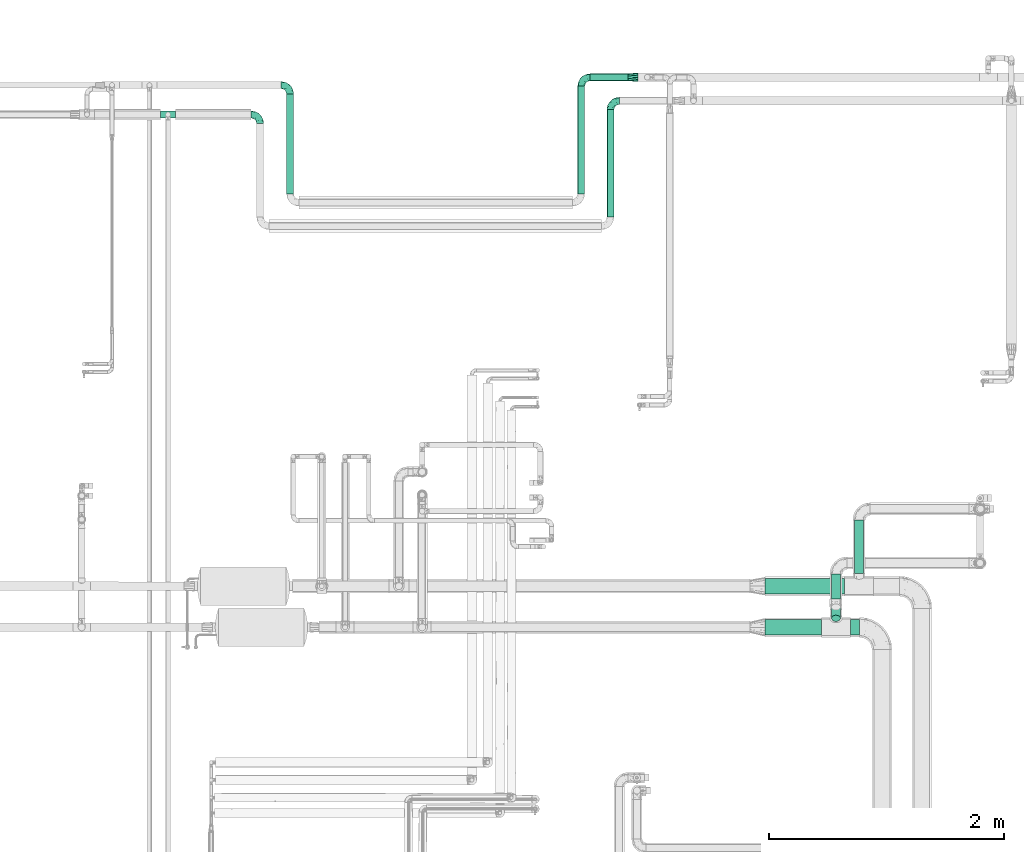
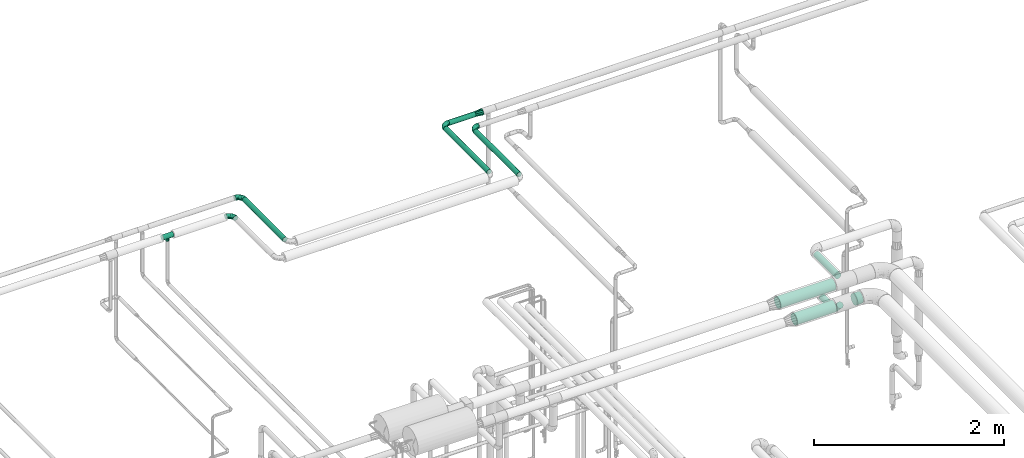
# One storey, part 582 of 827: 10 flow segments, 6 flow fittings.
"""IFC2X3 building model written with IfcOpenShell, lengths in millimetres."""

from ifc_helpers import new_model, entity, si_unit, converted_unit, derived_unit, direction, frame, origin, origin_2d_with_axis, place, context, subcontext, project, spatial, circle, extrude, faceted_brep, source, transform, mapped, material, type_object, type_shapes, element, save


model = new_model("IFC2X3")

# Units and contexts
model_context = context("Model", 3, precision=0.01, world=origin(), true_north=direction((6.12303176911189e-17, 1.0)))
body_context = subcontext(model_context, "Body", "Model", "MODEL_VIEW")
ifc_project = project(units=[si_unit("LENGTHUNIT", "METRE", prefix="MILLI"), si_unit("AREAUNIT", "SQUARE_METRE"), si_unit("VOLUMEUNIT", "CUBIC_METRE"), converted_unit("PLANEANGLEUNIT", "DEGREE", entity("IfcRatioMeasure", 0.0174532925199433), si_unit("PLANEANGLEUNIT", "RADIAN"), dimensions=[0, 0, 0, 0, 0, 0, 0]), si_unit("MASSUNIT", "GRAM", prefix="KILO"), derived_unit("MASSDENSITYUNIT", [(si_unit("MASSUNIT", "GRAM", prefix="KILO"), 1), (si_unit("LENGTHUNIT", "METRE"), -3)]), derived_unit("MOMENTOFINERTIAUNIT", [(si_unit("LENGTHUNIT", "METRE"), 4)]), si_unit("TIMEUNIT", "SECOND"), si_unit("FREQUENCYUNIT", "HERTZ"), si_unit("THERMODYNAMICTEMPERATUREUNIT", "DEGREE_CELSIUS"), derived_unit("THERMALTRANSMITTANCEUNIT", [(si_unit("MASSUNIT", "GRAM", prefix="KILO"), 1), (si_unit("THERMODYNAMICTEMPERATUREUNIT", "KELVIN"), -1), (si_unit("TIMEUNIT", "SECOND"), -3)]), derived_unit("VOLUMETRICFLOWRATEUNIT", [(si_unit("LENGTHUNIT", "METRE"), 3), (si_unit("TIMEUNIT", "SECOND"), -1)]), derived_unit("MASSFLOWRATEUNIT", [(si_unit("MASSUNIT", "GRAM", prefix="KILO"), 1), (si_unit("TIMEUNIT", "SECOND"), -1)]), derived_unit("ROTATIONALFREQUENCYUNIT", [(si_unit("TIMEUNIT", "SECOND"), -1)]), si_unit("ELECTRICCURRENTUNIT", "AMPERE"), si_unit("ELECTRICVOLTAGEUNIT", "VOLT"), si_unit("POWERUNIT", "WATT"), si_unit("FORCEUNIT", "NEWTON", prefix="KILO"), si_unit("ILLUMINANCEUNIT", "LUX"), si_unit("LUMINOUSFLUXUNIT", "LUMEN"), si_unit("LUMINOUSINTENSITYUNIT", "CANDELA"), derived_unit("USERDEFINED", [(si_unit("MASSUNIT", "GRAM", prefix="KILO"), -1), (si_unit("LENGTHUNIT", "METRE"), -2), (si_unit("TIMEUNIT", "SECOND"), 3), (si_unit("LUMINOUSFLUXUNIT", "LUMEN"), 1)]), derived_unit("LINEARVELOCITYUNIT", [(si_unit("LENGTHUNIT", "METRE"), 1), (si_unit("TIMEUNIT", "SECOND"), -1)]), si_unit("PRESSUREUNIT", "PASCAL"), derived_unit("USERDEFINED", [(si_unit("LENGTHUNIT", "METRE"), -2), (si_unit("MASSUNIT", "GRAM", prefix="KILO"), 1), (si_unit("TIMEUNIT", "SECOND"), -2)]), derived_unit("LINEARFORCEUNIT", [(si_unit("MASSUNIT", "GRAM", prefix="KILO"), 1), (si_unit("LENGTHUNIT", "METRE"), 1), (si_unit("TIMEUNIT", "SECOND"), -2), (si_unit("LENGTHUNIT", "METRE"), -1)]), derived_unit("PLANARFORCEUNIT", [(si_unit("MASSUNIT", "GRAM", prefix="KILO"), 1), (si_unit("LENGTHUNIT", "METRE"), 1), (si_unit("TIMEUNIT", "SECOND"), -2), (si_unit("LENGTHUNIT", "METRE"), -2)])], contexts=[model_context])

# Site, building, storey
site_placement = place(None, origin())
site = spatial("IfcSite", under=ifc_project, at=site_placement, CompositionType="ELEMENT")
building_placement = place(site_placement, origin())
building = spatial("IfcBuilding", under=site, at=building_placement, CompositionType="ELEMENT")
storey_placement = place(building_placement, frame((0.0, 0.0, 28200.0)))
storey = spatial("IfcBuildingStorey", under=building, at=storey_placement, Name="08", CompositionType="ELEMENT", Elevation=28200.0)

# Flow segments
pipe_segment_type_1 = type_object("IfcPipeSegmentType", PredefinedType="NOTDEFINED")
flow_segment_1_placement = place(storey_placement, frame((20840.57, 14681.7, 2731.9)))
element("IfcFlowSegment", 1, at=flow_segment_1_placement, inside=storey, type_object=pipe_segment_type_1, context=body_context, shape_type="SweptSolid", body=[
    extrude(circle(Radius=66.5, at=origin_2d_with_axis()), frame((0.0, 68.1, 68.1), z_axis=(1.0, 0.0, 0.0), x_axis=(0.0, 1.0, 0.0)), (0.0, 0.0, 1.0), 674.888161022038),
])
flow_segment_2_placement = place(storey_placement, frame((20839.9, 14331.9, 2731.89)))
element("IfcFlowSegment", 2, at=flow_segment_2_placement, inside=storey, type_object=pipe_segment_type_1, context=body_context, shape_type="SweptSolid", body=[
    extrude(circle(Radius=66.5, at=origin_2d_with_axis()), frame((0.0, 68.1, 68.1), z_axis=(1.0, 0.0, 0.0), x_axis=(0.0, 1.0, 0.0)), (0.0, 0.0, 1.0), 479.661433164736),
])
flow_segment_3_placement = place(storey_placement, frame((21567.56, 14331.9, 2731.89)))
element("IfcFlowSegment", 3, at=flow_segment_3_placement, inside=storey, type_object=pipe_segment_type_1, context=body_context, shape_type="SweptSolid", body=[
    extrude(circle(Radius=66.5, at=origin_2d_with_axis()), frame((0.0, 68.1, 68.1), z_axis=(1.0, 0.0, 0.0), x_axis=(0.0, 1.0, 0.0)), (0.0, 0.0, 1.0), 77.5493693479121),
])
pipe_segment_type_2 = type_object("IfcPipeSegmentType", PredefinedType="NOTDEFINED")
flow_segment_4_placement = place(storey_placement, frame((19492.58, 17888.97, 2968.4)))
element("IfcFlowSegment", 4, at=flow_segment_4_placement, inside=storey, type_object=pipe_segment_type_2, context=body_context, shape_type="SweptSolid", body=[
    extrude(circle(Radius=30.0, at=origin_2d_with_axis()), frame((31.6, 0.0, 31.6), z_axis=(0.0, 1.0, 0.0), x_axis=(1.0, 0.0, 0.0)), (0.0, 0.0, 1.0), 915.024836311617),
])
flow_segment_5_placement = place(storey_placement, frame((16767.47, 18088.8, 2968.4)))
element("IfcFlowSegment", 5, at=flow_segment_5_placement, inside=storey, type_object=pipe_segment_type_2, context=body_context, shape_type="SweptSolid", body=[
    extrude(circle(Radius=30.0, at=origin_2d_with_axis()), frame((31.6, 0.0, 31.6), z_axis=(0.0, 1.0, 0.0), x_axis=(-1.0, 0.0, 0.0)), (0.0, 0.0, 1.0), 848.667614532887),
])
flow_segment_6_placement = place(storey_placement, frame((19244.34, 18088.8, 2968.4)))
element("IfcFlowSegment", 6, at=flow_segment_6_placement, inside=storey, type_object=pipe_segment_type_2, context=body_context, shape_type="SweptSolid", body=[
    extrude(circle(Radius=30.0, at=origin_2d_with_axis()), frame((31.6, 0.0, 31.6), z_axis=(0.0, 1.0, 0.0), x_axis=(1.0, 0.0, 0.0)), (0.0, 0.0, 1.0), 915.200087128412),
])
flow_segment_7_placement = place(storey_placement, frame((19351.94, 19048.4, 2968.4)))
element("IfcFlowSegment", 7, at=flow_segment_7_placement, inside=storey, type_object=pipe_segment_type_2, context=body_context, shape_type="SweptSolid", body=[
    extrude(circle(Radius=30.0, at=origin_2d_with_axis()), frame((0.0, 31.6, 31.6), z_axis=(1.0, 0.0, 0.0), x_axis=(0.0, -1.0, 0.0)), (0.0, 0.0, 1.0), 320.274194256922),
])
flow_segment_8_placement = place(storey_placement, frame((21600.11, 14857.79, 2760.58)))
element("IfcFlowSegment", 8, at=flow_segment_8_placement, inside=storey, type_object=pipe_segment_type_2, context=body_context, shape_type="SweptSolid", body=[
    extrude(circle(Radius=37.75, at=origin_2d_with_axis()), frame((39.35, 0.0, 39.35), z_axis=(0.0, 1.0, 0.0), x_axis=(1.0, 0.0, 0.0)), (0.0, 0.0, 1.0), 454.453486275236),
])
flow_segment_9_placement = place(storey_placement, frame((21404.21, 14639.33, 2560.65)))
element("IfcFlowSegment", 9, at=flow_segment_9_placement, inside=storey, type_object=pipe_segment_type_2, context=body_context, shape_type="SweptSolid", body=[
    extrude(circle(Radius=37.75, at=origin_2d_with_axis()), frame((39.35, 0.0, 39.35), z_axis=(0.0, 1.0, 0.0), x_axis=(-1.0, 0.0, 0.0)), (0.0, 0.0, 1.0), 212.915947966477),
])
flow_segment_10_placement = place(storey_placement, frame((21404.21, 14448.08, 2599.54)))
element("IfcFlowSegment", 10, at=flow_segment_10_placement, inside=storey, type_object=pipe_segment_type_2, context=body_context, shape_type="SweptSolid", body=[
    extrude(circle(Radius=37.75, at=origin_2d_with_axis()), frame((39.35, 124.08, 28.29), z_axis=(0.0, -0.70710678118654, 0.707106781186556), x_axis=(-1.0, 0.0, 0.0)), (0.0, 0.0, 1.0), 135.468236750256),
])

# Flow fittings
ifc_material = material()
pipe_fitting_type_1 = type_object("IfcPipeFittingType", Name="ADSK_1", PredefinedType="NOTDEFINED", material=ifc_material)
shared_shape_1 = source(origin(), body_context, "Body", "Brep", [
    faceted_brep([(-76.0, 15.07, -26.11), (-76.0, 7.8, -29.12), (-76.0, 0.0, -30.15), (-76.0, -7.8, -29.12), (-76.0, -15.08, -26.11), (-76.0, -21.32, -21.32), (-76.0, -26.11, -15.08), (-76.0, -29.12, -7.8), (-76.0, -30.15, 0.0), (-76.0, -29.12, 7.8), (-76.0, -26.11, 15.07), (-76.0, -21.32, 21.32), (-76.0, -15.08, 26.11), (-76.0, -7.8, 29.12), (-76.0, 0.0, 30.15), (-76.0, 7.8, 29.12), (-76.0, 15.07, 26.11), (-76.0, 21.32, 21.32), (-76.0, 26.11, 15.07), (-76.0, 29.12, 7.8), (-76.0, 30.15, 0.0), (-76.0, 29.12, -7.8), (-76.0, 26.11, -15.08), (-76.0, 21.32, -21.32), (0.0, 76.0, -30.15), (-7.8, 76.0, -29.12), (-15.07, 76.0, -26.11), (-21.32, 76.0, -21.32), (-26.11, 76.0, -15.08), (-29.12, 76.0, -7.8), (-30.15, 76.0, 0.0), (-29.12, 76.0, 7.8), (-26.11, 76.0, 15.07), (-21.32, 76.0, 21.32), (-15.07, 76.0, 26.11), (-7.8, 76.0, 29.12), (0.0, 76.0, 30.15), (7.8, 76.0, 29.12), (15.08, 76.0, 26.11), (21.32, 76.0, 21.32), (26.11, 76.0, 15.07), (29.12, 76.0, 7.8), (30.15, 76.0, 0.0), (29.12, 76.0, -7.8), (26.11, 76.0, -15.08), (21.32, 76.0, -21.32), (15.08, 76.0, -26.11), (7.8, 76.0, -29.12), (10.79, 31.43, 21.07), (4.32, 31.7, 25.72), (1.65, 15.19, 19.92), (-61.17, -27.8, 0.0), (-51.1, -25.49, 9.84), (-56.14, -10.61, 27.27), (-31.7, -4.32, 25.72), (-39.75, 1.72, 29.41), (-43.2, -24.95, 0.0), (-1.86, 1.86, 0.0), (4.49, 7.65, 5.78), (-7.82, -4.61, 5.83), (-56.21, -22.79, 17.21), (-58.98, -3.38, 29.7), (-53.96, 5.6, 30.07), (-10.86, 10.86, 25.48), (-17.2, -2.6, 20.44), (-49.15, -16.01, 22.7), (-22.18, -14.24, 7.99), (-28.4, -17.42, 0.0), (-13.61, -9.88, 0.0), (-39.0, 23.48, 27.76), (-58.76, 12.54, 28.36), (-41.61, 15.41, 29.48), (16.01, 49.15, 22.7), (-58.55, 25.93, 19.53), (-51.53, 33.5, 13.51), (-64.92, 28.76, 12.4), (-7.48, 23.14, 28.25), (-1.72, 39.75, 29.41), (-12.04, 27.88, 29.88), (-63.91, 18.81, 24.52), (-11.63, 65.16, 28.18), (-4.97, 57.02, 30.05), (9.88, 13.61, 0.0), (-62.5, 31.74, 5.02), (-45.17, 30.98, 21.2), (-21.78, 9.76, 28.58), (10.61, 56.14, 27.27), (-32.09, 54.42, 13.26), (22.79, 56.21, 17.21), (15.38, 31.17, 15.63), (25.49, 51.1, 9.84), (21.84, 36.35, 5.92), (24.95, 43.2, 0.0), (3.38, 58.98, 29.7), (-31.17, -15.38, 15.63), (-39.39, 41.78, 15.45), (-34.56, 41.13, 20.79), (-39.81, -23.25, 5.49), (27.8, 61.17, 0.0), (-31.74, 62.5, 5.02), (-53.07, 36.29, 0.0), (-42.95, 42.95, 7.29), (-36.29, 53.07, 0.0), (-19.83, 58.51, 24.79), (-25.48, 60.2, 19.41), (-14.53, 50.96, 28.57), (-13.31, 37.09, 30.07), (-26.16, 40.06, 26.4), (-32.43, -10.35, 21.9), (17.42, 28.4, 0.0), (14.24, 22.18, 7.99), (-38.67, 9.72, 30.15), (-24.66, 17.36, 30.09), (-37.08, 31.49, 24.99), (-49.27, 22.83, 25.24), (-20.8, 38.81, 28.63), (-27.58, 27.58, 29.2), (-36.07, -20.23, 10.71), (-15.19, -6.16, 14.9), (6.6, 15.4, 14.49), (-2.51, 2.51, 11.35), (-65.16, 11.63, -28.18), (-49.15, -16.01, -22.7), (-57.02, 4.97, -30.05), (-25.93, 58.55, -19.53), (-33.5, 51.53, -13.51), (-28.76, 64.92, -12.4), (-60.2, 25.48, -19.41), (-58.51, 19.83, -24.79), (4.61, 7.82, -5.83), (-7.65, -4.49, -5.78), (-2.51, 2.51, -11.35), (-62.5, 31.74, -5.02), (-50.96, 14.53, -28.57), (-37.09, 13.31, -30.07), (-42.95, 42.95, -7.29), (25.49, 51.1, -9.84), (22.79, 56.21, -17.21), (-40.06, 26.16, -26.4), (3.38, 58.98, -29.7), (-5.6, 53.96, -30.07), (-27.88, 12.04, -29.88), (-9.76, 21.78, -28.58), (-23.14, 7.48, -28.25), (-51.1, -25.49, -9.84), (15.38, 31.17, -15.63), (16.01, 49.15, -22.7), (-23.48, 39.0, -27.76), (-12.54, 58.76, -28.36), (-15.41, 41.61, -29.48), (-56.21, -22.79, -17.21), (-9.72, 38.67, -30.15), (-17.36, 24.66, -30.09), (-22.18, -14.24, -7.99), (-41.13, 34.56, -20.79), (-31.74, 62.5, -5.02), (-58.98, -3.38, -29.7), (-31.17, -15.38, -15.63), (-56.14, -10.61, -27.27), (14.24, 22.18, -7.99), (23.25, 39.81, -5.49), (-31.49, 37.08, -24.99), (-15.19, -6.16, -14.9), (1.65, 15.19, -19.92), (-18.81, 63.91, -24.52), (-32.59, -11.62, -20.84), (-31.7, -4.32, -25.72), (-17.2, -2.6, -20.44), (-39.75, 1.72, -29.41), (-54.42, 32.09, -13.26), (-30.98, 45.17, -21.2), (10.61, 56.14, -27.27), (10.23, 31.31, -21.52), (4.32, 31.7, -25.72), (-41.78, 39.39, -15.45), (-1.72, 39.75, -29.41), (-36.35, -21.84, -5.92), (-22.83, 49.27, -25.24), (-38.81, 20.8, -28.63), (-27.58, 27.58, -29.2), (-10.86, 10.86, -25.48), (20.23, 36.07, -10.71), (6.6, 15.4, -14.49)], [[[0, 1, 2, 3, 4, 5, 6, 7, 8, 9, 10, 11, 12, 13, 14, 15, 16, 17, 18, 19, 20, 21, 22, 23]], [[24, 25, 26, 27, 28, 29, 30, 31, 32, 33, 34, 35, 36, 37, 38, 39, 40, 41, 42, 43, 44, 45, 46, 47]], [[48, 49, 50]], [[51, 52, 9]], [[53, 54, 55]], [[9, 52, 10]], [[56, 52, 51]], [[57, 58, 59]], [[11, 10, 60]], [[14, 61, 62]], [[63, 54, 64]], [[65, 12, 11]], [[65, 53, 12]], [[66, 67, 68]], [[69, 70, 71]], [[72, 39, 38]], [[73, 74, 75]], [[15, 70, 16]], [[76, 77, 78]], [[16, 79, 17]], [[13, 61, 14]], [[35, 80, 81]], [[14, 62, 15]], [[17, 73, 18]], [[57, 82, 58]], [[20, 19, 83]], [[75, 19, 18]], [[70, 15, 62]], [[73, 84, 74]], [[78, 85, 76]], [[38, 86, 72]], [[32, 31, 87]], [[88, 89, 90]], [[91, 92, 90]], [[72, 86, 49]], [[36, 93, 37]], [[75, 83, 19]], [[36, 35, 81]], [[60, 94, 65]], [[40, 90, 41]], [[95, 96, 87]], [[88, 90, 40]], [[66, 97, 67]], [[90, 98, 41]], [[40, 39, 88]], [[99, 31, 30]], [[20, 83, 100]], [[101, 102, 100]], [[52, 60, 10]], [[102, 99, 30]], [[96, 103, 104]], [[83, 101, 100]], [[12, 53, 13]], [[104, 103, 33]], [[105, 106, 81]], [[107, 105, 103]], [[64, 54, 108]], [[80, 103, 105]], [[80, 35, 34]], [[34, 33, 103]], [[86, 38, 37]], [[109, 110, 82]], [[71, 111, 112]], [[69, 107, 113]], [[79, 73, 17]], [[114, 113, 84]], [[33, 32, 104]], [[115, 107, 116]], [[105, 115, 106]], [[93, 81, 77]], [[54, 53, 65]], [[61, 53, 55]], [[108, 94, 64]], [[54, 63, 85]], [[93, 86, 37]], [[77, 76, 49]], [[77, 49, 86]], [[49, 63, 50]], [[60, 52, 117]], [[65, 11, 60]], [[39, 72, 88]], [[89, 88, 72]], [[71, 70, 62]], [[79, 70, 114]], [[103, 96, 107]], [[69, 113, 114]], [[112, 106, 116]], [[77, 81, 106]], [[112, 116, 71]], [[112, 55, 85]], [[64, 50, 63]], [[57, 59, 68]], [[32, 87, 104]], [[96, 104, 87]], [[94, 118, 64]], [[50, 119, 89]], [[50, 64, 118]], [[50, 89, 48]], [[81, 93, 36]], [[86, 93, 77]], [[53, 61, 13]], [[62, 61, 55]], [[71, 62, 111]], [[69, 71, 116]], [[95, 101, 74]], [[99, 101, 87]], [[118, 66, 59]], [[117, 97, 66]], [[117, 66, 94]], [[91, 89, 110]], [[91, 110, 109]], [[110, 89, 119]], [[9, 8, 51]], [[98, 90, 92]], [[98, 42, 41]], [[101, 83, 74]], [[101, 99, 102]], [[87, 31, 99]], [[62, 55, 111]], [[55, 112, 111]], [[107, 69, 116]], [[70, 69, 114]], [[107, 96, 113]], [[84, 113, 96]], [[84, 96, 95]], [[114, 84, 73]], [[70, 79, 16]], [[73, 79, 114]], [[54, 85, 55]], [[76, 85, 63]], [[49, 76, 63]], [[77, 106, 78]], [[106, 112, 78]], [[85, 78, 112]], [[73, 75, 18]], [[83, 75, 74]], [[103, 80, 34]], [[81, 80, 105]], [[101, 95, 87]], [[84, 95, 74]], [[106, 115, 116]], [[105, 107, 115]], [[120, 59, 58]], [[82, 110, 58]], [[119, 58, 110]], [[118, 59, 120]], [[66, 68, 59]], [[54, 65, 108]], [[94, 108, 65]], [[66, 118, 94]], [[50, 118, 120]], [[50, 120, 119]], [[119, 120, 58]], [[89, 72, 48]], [[49, 48, 72]], [[60, 117, 94]], [[117, 52, 97]], [[52, 56, 97]], [[67, 97, 56]], [[92, 91, 109]], [[89, 91, 90]], [[121, 1, 0]], [[122, 5, 4]], [[2, 1, 123]], [[124, 125, 126]], [[127, 128, 23]], [[129, 130, 131]], [[100, 132, 20]], [[133, 134, 123]], [[135, 100, 102]], [[136, 137, 44]], [[133, 128, 138]], [[24, 139, 140]], [[141, 142, 143]], [[121, 128, 133]], [[6, 144, 7]], [[137, 145, 146]], [[144, 51, 7]], [[147, 148, 149]], [[144, 6, 150]], [[149, 151, 152]], [[153, 68, 67]], [[154, 128, 127]], [[30, 155, 102]], [[43, 42, 98]], [[156, 3, 2]], [[157, 144, 150]], [[158, 4, 3]], [[24, 140, 25]], [[155, 135, 102]], [[159, 160, 109]], [[30, 29, 155]], [[147, 138, 161]], [[27, 124, 28]], [[57, 129, 82]], [[162, 163, 131]], [[27, 26, 164]], [[148, 26, 25]], [[165, 166, 167]], [[24, 47, 139]], [[143, 168, 141]], [[22, 21, 169]], [[125, 124, 170]], [[148, 25, 140]], [[46, 146, 171]], [[158, 122, 4]], [[0, 23, 128]], [[1, 121, 123]], [[109, 82, 159]], [[45, 44, 137]], [[146, 46, 45]], [[136, 43, 98]], [[132, 21, 20]], [[136, 98, 92]], [[172, 173, 146]], [[46, 171, 47]], [[43, 136, 44]], [[174, 154, 169]], [[171, 173, 175]], [[6, 5, 150]], [[126, 29, 28]], [[176, 56, 144]], [[122, 158, 166]], [[164, 124, 27]], [[177, 161, 170]], [[23, 22, 127]], [[178, 138, 179]], [[133, 178, 134]], [[156, 123, 168]], [[156, 158, 3]], [[168, 143, 166]], [[168, 166, 158]], [[166, 180, 167]], [[173, 171, 146]], [[139, 171, 175]], [[172, 145, 163]], [[173, 180, 142]], [[5, 122, 150]], [[157, 150, 122]], [[137, 136, 181]], [[146, 45, 137]], [[149, 148, 140]], [[164, 148, 177]], [[128, 154, 138]], [[147, 161, 177]], [[152, 134, 179]], [[168, 123, 134]], [[152, 179, 149]], [[152, 175, 142]], [[57, 130, 129]], [[157, 165, 167]], [[22, 169, 127]], [[154, 127, 169]], [[163, 167, 180]], [[162, 157, 167]], [[173, 163, 180]], [[182, 163, 145]], [[123, 156, 2]], [[158, 156, 168]], [[171, 139, 47]], [[140, 139, 175]], [[149, 140, 151]], [[147, 149, 179]], [[174, 135, 125]], [[132, 135, 169]], [[176, 157, 153]], [[176, 153, 67]], [[153, 157, 162]], [[182, 159, 129]], [[181, 160, 159]], [[181, 159, 145]], [[51, 144, 56]], [[51, 8, 7]], [[135, 132, 100]], [[169, 21, 132]], [[126, 155, 29]], [[135, 155, 125]], [[140, 175, 151]], [[175, 152, 151]], [[138, 147, 179]], [[148, 147, 177]], [[138, 154, 161]], [[170, 161, 154]], [[170, 154, 174]], [[177, 170, 124]], [[148, 164, 26]], [[124, 164, 177]], [[173, 142, 175]], [[143, 142, 180]], [[166, 143, 180]], [[168, 134, 141]], [[134, 152, 141]], [[142, 141, 152]], [[124, 126, 28]], [[155, 126, 125]], [[128, 121, 0]], [[123, 121, 133]], [[135, 174, 169]], [[170, 174, 125]], [[134, 178, 179]], [[133, 138, 178]], [[130, 153, 162]], [[68, 153, 130]], [[57, 68, 130]], [[182, 129, 131]], [[159, 82, 129]], [[157, 122, 165]], [[166, 165, 122]], [[163, 162, 167]], [[162, 131, 130]], [[145, 172, 146]], [[163, 173, 172]], [[159, 182, 145]], [[131, 163, 182]], [[56, 176, 67]], [[157, 176, 144]], [[137, 181, 145]], [[181, 136, 160]], [[136, 92, 160]], [[109, 160, 92]]]),
])
type_shapes(pipe_fitting_type_1, [shared_shape_1])
for number, where, z_axis, x_axis, name in (
    (11, (16544.17, 18762.97, 3000.0), (0.0, 0.0, 1.0), (0.0, 1.0, 0.0), "ADSK_1"),
    (12, (19524.17, 18880.0, 3000.0), (0.0, 0.0, 1.0), (-1.0, 0.0, 0.0), "ADSK_1"),
    (13, (16799.06, 19013.47, 3000.0), (0.0, 0.0, 1.0), (0.0, 1.0, 0.0), "ADSK_1"),
    (14, (19275.94, 19080.0, 3000.0), (0.0, 0.0, 1.0), (-1.0, 0.0, 0.0), "ADSK_1"),
):
    element("IfcFlowFitting", number, at=place(storey_placement, frame(where, z_axis=z_axis, x_axis=x_axis)), inside=storey, type_object=pipe_fitting_type_1, material=ifc_material, Name=name, ObjectType="ADSK_1", context=body_context, shape_type="MappedRepresentation", body=[
        mapped(shared_shape_1, transform((0.0, 0.0, 0.0), scale=1.0)),
    ])
pipe_fitting_type_2 = type_object("IfcPipeFittingType", Name="ADSK_1", PredefinedType="NOTDEFINED", material=ifc_material)
shared_shape_2 = source(origin(), body_context, "Body", "Brep", [
    faceted_brep([(-64.0, 15.07, -26.11), (-64.0, 7.8, -29.12), (-64.0, 0.0, -30.15), (-64.0, -7.8, -29.12), (-64.0, -15.08, -26.11), (-64.0, -21.32, -21.32), (-64.0, -26.11, -15.08), (-64.0, -29.12, -7.8), (-64.0, -30.15, 0.0), (-64.0, -29.12, 7.8), (-64.0, -26.11, 15.07), (-64.0, -21.32, 21.32), (-64.0, -15.08, 26.11), (-64.0, -7.8, 29.12), (-64.0, 0.0, 30.15), (-64.0, 7.8, 29.12), (-64.0, 15.07, 26.11), (-64.0, 21.32, 21.32), (-64.0, 26.11, 15.07), (-64.0, 29.12, 7.8), (-64.0, 30.15, 0.0), (-64.0, 29.12, -7.8), (-64.0, 26.11, -15.08), (-64.0, 21.32, -21.32), (64.0, 0.0, -30.15), (64.0, 7.8, -29.12), (64.0, 15.07, -26.11), (64.0, 21.32, -21.32), (64.0, 26.11, -15.08), (64.0, 29.12, -7.8), (64.0, 30.15, 0.0), (64.0, 29.12, 7.8), (64.0, 26.11, 15.07), (64.0, 21.32, 21.32), (64.0, 15.07, 26.11), (64.0, 7.8, 29.12), (64.0, 0.0, 30.15), (64.0, -7.8, 29.12), (64.0, -15.08, 26.11), (64.0, -21.32, 21.32), (64.0, -26.11, 15.07), (64.0, -29.12, 7.8), (64.0, -30.15, 0.0), (64.0, -29.12, -7.8), (64.0, -26.11, -15.08), (64.0, -21.32, -21.32), (64.0, -15.08, -26.11), (64.0, -7.8, -29.12), (19.84, -29.21, 7.47), (20.52, -29.68, 3.73), (21.2, -30.15, 0.0), (16.14, -26.84, 13.74), (10.7, -23.96, 18.3), (3.81, -21.77, 20.85), (-3.82, -21.77, 20.85), (0.0, -21.77, 20.85), (-21.2, -30.15, 0.0), (-20.52, -29.68, 3.73), (-19.84, -29.21, 7.47), (-16.15, -26.84, 13.74), (-10.7, -23.96, 18.3), (3.81, -21.77, -20.85), (10.7, -23.96, -18.3), (16.14, -26.84, -13.74), (0.0, -21.77, -20.85), (-3.82, -21.77, -20.85), (19.84, -29.21, -7.47), (20.52, -29.68, -3.73), (-10.7, -23.96, -18.3), (-16.15, -26.84, -13.74), (-19.84, -29.21, -7.47), (-20.52, -29.68, -3.73), (0.0, -57.0, -21.2), (5.49, -57.0, -20.48), (10.6, -57.0, -18.36), (14.99, -57.0, -14.99), (18.36, -57.0, -10.6), (20.48, -57.0, -5.49), (21.2, -57.0, 0.0), (20.48, -57.0, 5.49), (18.36, -57.0, 10.6), (14.99, -57.0, 14.99), (10.6, -57.0, 18.36), (5.49, -57.0, 20.48), (0.0, -57.0, 21.2), (-5.49, -57.0, 20.48), (-10.6, -57.0, 18.36), (-14.99, -57.0, 14.99), (-18.36, -57.0, 10.6), (-20.48, -57.0, 5.49), (-21.2, -57.0, 0.0), (-20.48, -57.0, -5.49), (-18.36, -57.0, -10.6), (-14.99, -57.0, -14.99), (-10.6, -57.0, -18.36), (-5.49, -57.0, -20.48)], [[[0, 1, 2, 3, 4, 5, 6, 7, 8, 9, 10, 11, 12, 13, 14, 15, 16, 17, 18, 19, 20, 21, 22, 23]], [[24, 25, 26, 27, 28, 29, 30, 31, 32, 33, 34, 35, 36, 37, 38, 39, 40, 41, 42, 43, 44, 45, 46, 47]], [[42, 41, 48]], [[42, 48, 49, 50]], [[41, 51, 48]], [[40, 39, 52]], [[52, 51, 40]], [[53, 52, 39]], [[12, 54, 55, 53]], [[40, 51, 41]], [[8, 56, 57, 58]], [[9, 8, 58]], [[58, 59, 9]], [[60, 54, 11]], [[60, 10, 59]], [[10, 60, 11]], [[59, 10, 9]], [[11, 54, 12]], [[53, 39, 38]], [[14, 13, 37, 36]], [[13, 12, 38, 37]], [[15, 14, 36, 35]], [[32, 31, 19, 18]], [[17, 16, 34, 33]], [[18, 17, 33, 32]], [[35, 34, 16, 15]], [[20, 19, 31, 30]], [[38, 12, 53]], [[29, 28, 22, 21]], [[28, 27, 23, 22]], [[30, 29, 21, 20]], [[24, 47, 3, 2]], [[1, 0, 26, 25]], [[2, 1, 25, 24]], [[27, 26, 0, 23]], [[4, 3, 47, 46]], [[46, 61, 4]], [[45, 44, 62]], [[62, 61, 45]], [[44, 63, 62]], [[4, 61, 64, 65]], [[43, 42, 66]], [[66, 63, 43]], [[42, 50, 67, 66]], [[43, 63, 44]], [[65, 68, 5]], [[6, 5, 68]], [[68, 69, 6]], [[5, 4, 65]], [[69, 70, 7]], [[70, 8, 7]], [[8, 70, 71, 56]], [[69, 7, 6]], [[61, 46, 45]], [[72, 73, 74, 75, 76, 77, 78, 79, 80, 81, 82, 83, 84, 85, 86, 87, 88, 89, 90, 91, 92, 93, 94, 95]], [[57, 90, 89]], [[49, 78, 50]], [[60, 87, 86]], [[84, 54, 85]], [[49, 48, 79]], [[60, 86, 85]], [[89, 58, 57]], [[56, 90, 57]], [[58, 89, 88]], [[58, 88, 59]], [[87, 59, 88]], [[87, 60, 59]], [[85, 54, 60]], [[84, 53, 55, 54]], [[52, 83, 82]], [[81, 52, 82]], [[48, 80, 79]], [[81, 80, 51]], [[53, 84, 83]], [[83, 52, 53]], [[52, 81, 51]], [[51, 80, 48]], [[78, 49, 79]], [[77, 67, 78]], [[63, 76, 75]], [[72, 61, 73]], [[77, 66, 67]], [[76, 66, 77]], [[74, 62, 75]], [[67, 50, 78]], [[66, 76, 63]], [[62, 73, 61]], [[62, 63, 75]], [[72, 65, 64, 61]], [[62, 74, 73]], [[71, 70, 91]], [[68, 95, 94]], [[93, 68, 94]], [[70, 92, 91]], [[93, 92, 69]], [[65, 72, 95]], [[95, 68, 65]], [[68, 93, 69]], [[69, 92, 70]], [[90, 71, 91]], [[71, 90, 56]]]),
])
type_shapes(pipe_fitting_type_2, [shared_shape_2])
flow_fitting_1_placement = place(storey_placement, frame((15760.94, 18762.97, 3000.0), z_axis=(0.0, 1.0, 0.0), x_axis=(-1.0, 0.0, 0.0)))
element("IfcFlowFitting", 15, at=flow_fitting_1_placement, inside=storey, type_object=pipe_fitting_type_2, material=ifc_material, Name="ADSK_1", ObjectType="ADSK_1", context=body_context, shape_type="MappedRepresentation", body=[
    mapped(shared_shape_2, transform((0.0, 0.0, 0.0), scale=1.0)),
])
pipe_fitting_type_3 = type_object("IfcPipeFittingType", Name="ADSK_1", PredefinedType="NOTDEFINED", material=ifc_material)
shared_shape_3 = source(origin(), body_context, "Body", "Brep", [
    faceted_brep([(89.0, -30.15, 0.0), (89.0, -27.27, -8.86), (89.0, -24.39, -17.72), (89.0, -16.85, -23.2), (89.0, -9.32, -28.67), (89.0, 0.0, -28.67), (89.0, 9.32, -28.67), (89.0, 16.85, -23.2), (89.0, 24.39, -17.72), (89.0, 27.27, -8.86), (89.0, 30.15, 0.0), (89.0, 27.27, 8.86), (89.0, 24.39, 17.72), (89.0, 16.85, 23.2), (89.0, 9.32, 28.67), (89.0, 0.0, 28.67), (89.0, -9.32, 28.67), (89.0, -16.85, 23.2), (89.0, -24.39, 17.72), (89.0, -27.27, 8.86), (0.0, -32.95, -19.03), (0.0, -36.11, -7.24), (0.0, -38.05, 0.0), (0.0, -36.11, 7.24), (0.0, -32.95, 19.02), (0.0, -25.99, 25.99), (0.0, -19.02, 32.95), (0.0, -9.51, 35.5), (0.0, 0.0, 38.05), (0.0, 9.51, 35.5), (0.0, 19.02, 32.95), (0.0, 25.99, 25.99), (0.0, 32.95, 19.02), (0.0, 36.11, 7.24), (0.0, 38.05, 0.0), (0.0, 36.11, -7.24), (0.0, 32.95, -19.02), (0.0, 25.99, -25.99), (0.0, 19.03, -32.95), (0.0, 9.51, -35.5), (0.0, 0.0, -38.05), (0.0, -9.51, -35.5), (0.0, -19.02, -32.95), (0.0, -25.99, -25.99)], [[[0, 1, 2, 3, 4, 5, 6, 7, 8, 9, 10, 11, 12, 13, 14, 15, 16, 17, 18, 19]], [[20, 21, 22, 23, 24, 25, 26, 27, 28, 29, 30, 31, 32, 33, 34, 35, 36, 37, 38, 39, 40, 41, 42, 43]], [[35, 9, 36]], [[42, 4, 3]], [[2, 43, 3]], [[2, 1, 20]], [[1, 0, 21]], [[7, 6, 38]], [[42, 3, 43]], [[43, 2, 20]], [[5, 39, 6]], [[41, 5, 4]], [[7, 37, 8]], [[4, 42, 41]], [[5, 40, 39]], [[9, 35, 10]], [[1, 21, 20]], [[39, 38, 6]], [[22, 21, 0]], [[8, 36, 9]], [[37, 36, 8]], [[35, 34, 10]], [[37, 7, 38]], [[40, 5, 41]], [[23, 19, 24]], [[30, 14, 13]], [[12, 31, 13]], [[12, 11, 32]], [[11, 10, 33]], [[17, 16, 26]], [[30, 13, 31]], [[31, 12, 32]], [[15, 27, 16]], [[29, 15, 14]], [[17, 25, 18]], [[14, 30, 29]], [[15, 28, 27]], [[19, 23, 0]], [[11, 33, 32]], [[27, 26, 16]], [[34, 33, 10]], [[18, 24, 19]], [[25, 24, 18]], [[23, 22, 0]], [[25, 17, 26]], [[28, 15, 29]]]),
])
type_shapes(pipe_fitting_type_3, [shared_shape_3])
flow_fitting_2_placement = place(storey_placement, frame((19761.21, 19080.0, 3000.0), z_axis=(0.0, 0.0, 1.0), x_axis=(-1.0, 0.0, 0.0)))
element("IfcFlowFitting", 16, at=flow_fitting_2_placement, inside=storey, type_object=pipe_fitting_type_3, material=ifc_material, Name="ADSK_1", ObjectType="ADSK_1", context=body_context, shape_type="MappedRepresentation", body=[
    mapped(shared_shape_3, transform((0.0, 0.0, 0.0), scale=1.0)),
])

save(model, "model.ifc")
